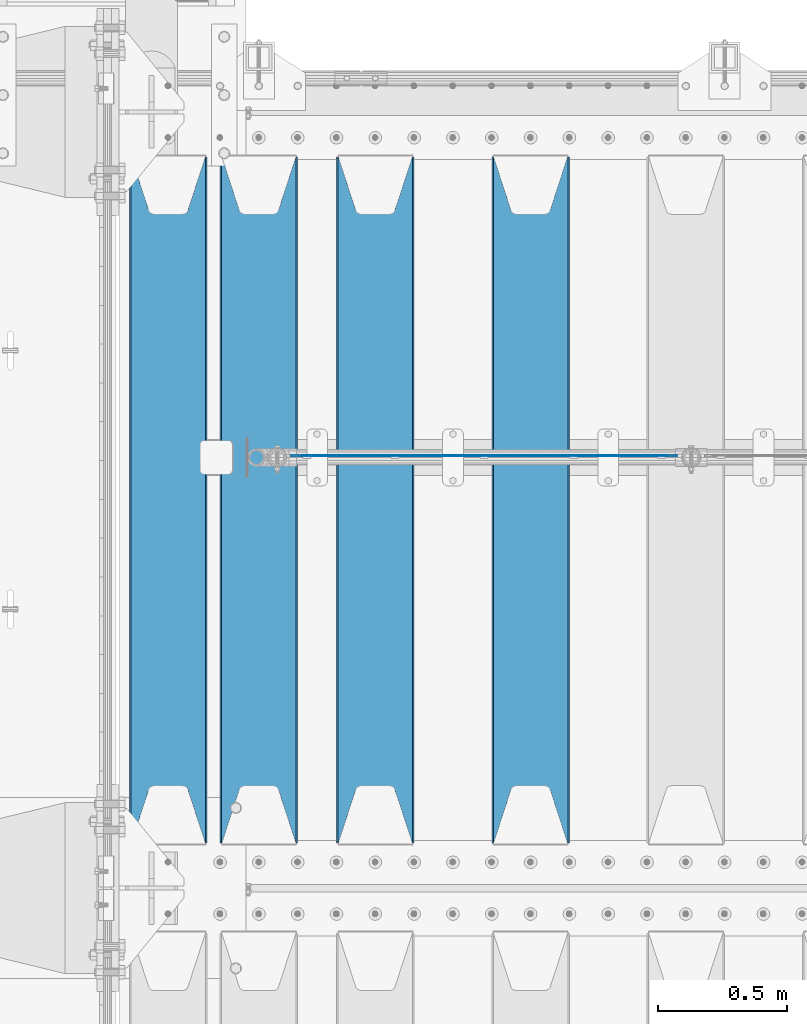
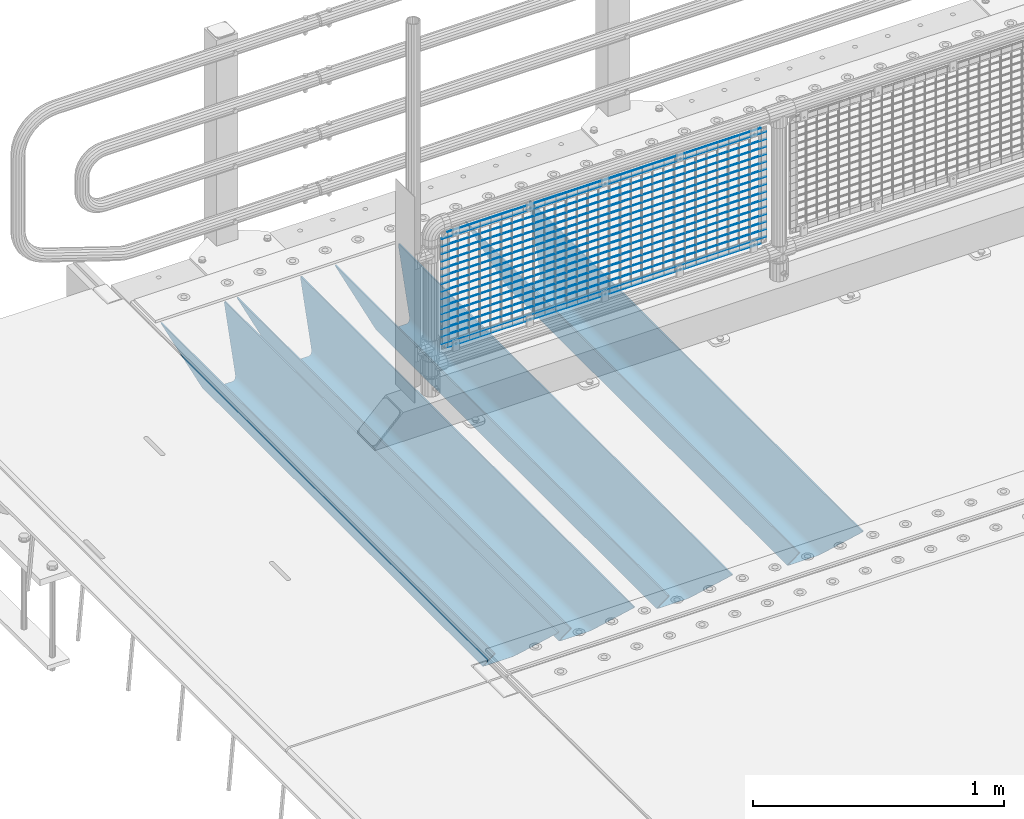
# One storey, part 93 of 208: 21 beams.
"""IFC2X3 building model written with IfcOpenShell, lengths in millimetres."""

from ifc_helpers import new_model, si_unit, frame, origin_with_axes, place, context, subcontext, project, spatial, faceted_brep, material, type_object, element, save


model = new_model("IFC2X3")

# Units and contexts
model_context = context("Model", 3, precision=1e-05, world=origin_with_axes())
body_context = subcontext(model_context, "Body", "Model", "MODEL_VIEW")
ifc_project = project(units=[si_unit("LENGTHUNIT", "METRE", prefix="MILLI"), si_unit("AREAUNIT", "SQUARE_METRE"), si_unit("VOLUMEUNIT", "CUBIC_METRE"), si_unit("MASSUNIT", "GRAM", prefix="KILO"), si_unit("TIMEUNIT", "SECOND"), si_unit("PLANEANGLEUNIT", "RADIAN"), si_unit("SOLIDANGLEUNIT", "STERADIAN"), si_unit("THERMODYNAMICTEMPERATUREUNIT", "DEGREE_CELSIUS"), si_unit("LUMINOUSINTENSITYUNIT", "LUMEN")], contexts=[model_context])

# Site, building, storey
site_placement = place(None, origin_with_axes())
site = spatial("IfcSite", under=ifc_project, at=site_placement, CompositionType="ELEMENT")
building_placement = place(site_placement, origin_with_axes())
building = spatial("IfcBuilding", under=site, at=building_placement, Name="Standard", CompositionType="ELEMENT")
storey_placement = place(building_placement, origin_with_axes())
storey = spatial("IfcBuildingStorey", under=building, at=storey_placement, Name="Undefined", CompositionType="ELEMENT", Elevation=0.0)

# Beams
ifc_material_1 = material(Name="STEEL/S355N")
beam_type_1 = type_object("IfcBeamType", PredefinedType="NOTDEFINED")
beam_1_placement = place(storey_placement, frame((-40850.0, 3175.0, -115.0), z_axis=(0.0, 0.0, 1.0), x_axis=(0.0, 1.0, 0.0)))
element("IfcBeam", 1, at=beam_1_placement, inside=storey, type_object=beam_type_1, material=ifc_material_1, context=body_context, shape_type="Brep", body=[
    faceted_brep([(0.0, 150.0, 115.0), (0.0, 143.689999999999, 115.0), (2650.00000000297, 143.689999999999, 115.0), (2650.00000000297, 150.0, 115.0), (2650.00000000297, 142.059565218402, 110.0000000031), (2650.00000000297, 148.369565218403, 110.0000000031), (2441.90079219208, -80.1103600731112, -98.0992078077845), (2437.7588105432, -77.5672621345584, -102.241189456673), (2434.06523489746, -74.4080125315522, -105.934765102404), (2430.91086095089, -70.710272125576, -109.089139048974), (2428.37322971128, -66.5649389910068, -111.626770288588), (2426.51472138055, -62.0739139532889, -113.485278619323), (2425.38102192091, -57.3475956567672, -114.618978078955), (2424.99999999987, -52.5021667386536, -115.0), (2424.99999999987, 52.5021667386536, -115.0), (2425.38102192091, 57.3475956567672, -114.618978078955), (2426.51472138055, 62.0739139532889, -113.485278619323), (2428.37322971128, 66.5649389910068, -111.626770288588), (2430.91086095089, 70.710272125576, -109.089139048974), (2434.06523489746, 74.4080125315522, -105.934765102404), (2437.7588105432, 77.5672621345584, -102.241189456673), (2441.90079219208, 80.1103600731112, -98.0992078077846), (2446.38936140511, 81.9747917625791, -93.6106385947584), (2448.24948500409, 76.2713538057251, -91.7505149957729), (2444.62967112262, 74.76777986261, -95.3703288772456), (2441.28936334126, 72.7168944282894, -98.710636658607), (2438.31067330438, 70.1691124903846, -101.689326695487), (2435.76682334747, 67.1870637758839, -104.233176652398), (2433.72034654133, 63.8440531834895, -106.279653458539), (2432.22154950041, 60.222258798236, -107.778450499454), (2431.30727574265, 56.4107117849089, -108.692724257221), (2430.99999999987, 52.5031078186876, -109.0), (2430.99999999987, -52.5031078186876, -109.0), (2431.30727574265, -56.4107117849089, -108.692724257221), (2432.22154950041, -60.222258798236, -107.778450499454), (2433.72034654133, -63.8440531834895, -106.279653458539), (2435.76682334747, -67.1870637758839, -104.233176652398), (2438.31067330438, -70.1691124903846, -101.689326695487), (2441.28936334126, -72.7168944282894, -98.7106366586071), (2444.62967112262, -74.76777986261, -95.3703288772457), (2448.24948500409, -76.2713538057251, -91.7505149957729), (2650.00000000297, -142.059565218402, 110.0000000031), (2650.00000000297, -148.369565218403, 110.0000000031), (2446.38936140511, -81.9747917625791, -93.6106385947584), (2650.00000000297, -143.689999999999, 115.0), (2650.00000000297, -150.0, 115.0), (0.0, -143.689999999999, 115.0), (0.0, -150.0, 115.0), (0.0, -148.369565218261, 110.000000002663), (203.610638597421, -81.9747917625791, -93.6106385947584), (208.099207810448, -80.1103600731112, -98.0992078077845), (212.241189459336, -77.5672621345584, -102.241189456673), (215.934765105067, -74.4080125315522, -105.934765102404), (219.089139051637, -70.710272125576, -109.089139048974), (221.626770291251, -66.5649389910068, -111.626770288588), (223.485278621986, -62.0739139532889, -113.485278619323), (224.618978081618, -57.3475956567672, -114.618978078955), (225.000000002663, -52.5021667386536, -115.0), (225.000000002663, 52.5021667386536, -115.0), (224.618978081618, 57.3475956567672, -114.618978078955), (223.485278621986, 62.0739139532889, -113.485278619323), (221.626770291251, 66.5649389910068, -111.626770288588), (219.089139051637, 70.710272125576, -109.089139048974), (215.934765105067, 74.4080125315522, -105.934765102404), (212.241189459336, 77.5672621345584, -102.241189456673), (208.099207810448, 80.1103600731112, -98.0992078077846), (203.610638597421, 81.9747917625791, -93.6106385947584), (0.0, 148.369565218261, 110.000000002663), (0.0, 142.05956521826, 110.000000002663), (201.750514998436, 76.2713538057251, -91.7505149957729), (205.370328879908, 74.76777986261, -95.3703288772456), (208.71063666127, 72.7168944282894, -98.710636658607), (211.68932669815, 70.1691124903846, -101.689326695487), (214.233176655061, 67.1870637758839, -104.233176652398), (216.279653461202, 63.8440531834895, -106.279653458539), (217.778450502116, 60.222258798236, -107.778450499454), (218.692724259884, 56.4107117849089, -108.692724257221), (219.000000002663, 52.5031078186876, -109.0), (219.000000002663, -52.5031078186876, -109.0), (218.692724259884, -56.4107117849089, -108.692724257221), (217.778450502116, -60.222258798236, -107.778450499454), (216.279653461202, -63.8440531834895, -106.279653458539), (214.233176655061, -67.1870637758839, -104.233176652398), (211.68932669815, -70.1691124903846, -101.689326695487), (208.71063666127, -72.7168944282894, -98.7106366586071), (205.370328879908, -74.76777986261, -95.3703288772457), (201.750514998436, -76.2713538057251, -91.7505149957729), (0.0, -142.05956521826, 110.000000002663)], [[[0, 1, 2, 3]], [[3, 2, 4, 5]], [[6, 7, 8, 9, 10, 11, 12, 13, 14, 15, 16, 17, 18, 19, 20, 21, 22, 5, 4, 23, 24, 25, 26, 27, 28, 29, 30, 31, 32, 33, 34, 35, 36, 37, 38, 39, 40, 41, 42, 43]], [[44, 45, 42, 41]], [[46, 47, 45, 44]], [[43, 42, 45, 47, 48, 49]], [[6, 43, 49, 50]], [[7, 6, 50, 51]], [[8, 7, 51, 52]], [[9, 8, 52, 53]], [[10, 9, 53, 54]], [[11, 10, 54, 55]], [[12, 11, 55, 56]], [[13, 12, 56, 57]], [[14, 13, 57, 58]], [[15, 14, 58, 59]], [[16, 15, 59, 60]], [[17, 16, 60, 61]], [[18, 17, 61, 62]], [[19, 18, 62, 63]], [[20, 19, 63, 64]], [[21, 20, 64, 65]], [[22, 21, 65, 66]], [[0, 3, 5, 22, 66, 67]], [[1, 0, 67, 68]], [[23, 4, 2, 1, 68, 69]], [[24, 23, 69, 70]], [[25, 24, 70, 71]], [[26, 25, 71, 72]], [[27, 26, 72, 73]], [[28, 27, 73, 74]], [[29, 28, 74, 75]], [[30, 29, 75, 76]], [[31, 30, 76, 77]], [[32, 31, 77, 78]], [[33, 32, 78, 79]], [[34, 33, 79, 80]], [[35, 34, 80, 81]], [[36, 35, 81, 82]], [[37, 36, 82, 83]], [[38, 37, 83, 84]], [[39, 38, 84, 85]], [[40, 39, 85, 86]], [[46, 44, 41, 40, 86, 87]], [[47, 46, 87, 48]], [[86, 85, 84, 83, 82, 81, 80, 79, 78, 77, 76, 75, 74, 73, 72, 71, 70, 69, 68, 67, 66, 65, 64, 63, 62, 61, 60, 59, 58, 57, 56, 55, 54, 53, 52, 51, 50, 49, 48, 87]]]),
])
beam_2_placement = place(storey_placement, frame((-41450.0, 3175.0, -115.0), z_axis=(0.0, 0.0, 1.0), x_axis=(0.0, 1.0, 0.0)))
element("IfcBeam", 2, at=beam_2_placement, inside=storey, type_object=beam_type_1, material=ifc_material_1, context=body_context, shape_type="Brep", body=[
    faceted_brep([(0.0, 150.0, 115.0), (0.0, 143.689999999999, 115.0), (2650.00000000297, 143.689999999999, 115.0), (2650.00000000297, 150.0, 115.0), (2650.00000000297, 142.059565218402, 110.0000000031), (2650.00000000297, 148.369565218403, 110.0000000031), (2441.90079219208, -80.1103600731112, -98.0992078077845), (2437.7588105432, -77.5672621345584, -102.241189456673), (2434.06523489746, -74.4080125315522, -105.934765102404), (2430.91086095089, -70.710272125576, -109.089139048974), (2428.37322971128, -66.5649389910068, -111.626770288588), (2426.51472138055, -62.0739139532889, -113.485278619323), (2425.38102192091, -57.3475956567672, -114.618978078955), (2424.99999999987, -52.5021667386536, -115.0), (2424.99999999987, 52.5021667386536, -115.0), (2425.38102192091, 57.3475956567672, -114.618978078955), (2426.51472138055, 62.0739139532889, -113.485278619323), (2428.37322971128, 66.5649389910068, -111.626770288588), (2430.91086095089, 70.710272125576, -109.089139048974), (2434.06523489746, 74.4080125315522, -105.934765102404), (2437.7588105432, 77.5672621345584, -102.241189456673), (2441.90079219208, 80.1103600731112, -98.0992078077846), (2446.38936140511, 81.9747917625791, -93.6106385947584), (2448.24948500409, 76.2713538057251, -91.7505149957729), (2444.62967112262, 74.76777986261, -95.3703288772456), (2441.28936334126, 72.7168944282894, -98.710636658607), (2438.31067330438, 70.1691124903846, -101.689326695487), (2435.76682334747, 67.1870637758839, -104.233176652398), (2433.72034654133, 63.8440531834895, -106.279653458539), (2432.22154950041, 60.222258798236, -107.778450499454), (2431.30727574265, 56.4107117849089, -108.692724257221), (2430.99999999987, 52.5031078186876, -109.0), (2430.99999999987, -52.5031078186876, -109.0), (2431.30727574265, -56.4107117849089, -108.692724257221), (2432.22154950041, -60.222258798236, -107.778450499454), (2433.72034654133, -63.8440531834895, -106.279653458539), (2435.76682334747, -67.1870637758839, -104.233176652398), (2438.31067330438, -70.1691124903846, -101.689326695487), (2441.28936334126, -72.7168944282894, -98.7106366586071), (2444.62967112262, -74.76777986261, -95.3703288772457), (2448.24948500409, -76.2713538057251, -91.7505149957729), (2650.00000000297, -142.059565218402, 110.0000000031), (2650.00000000297, -148.369565218403, 110.0000000031), (2446.38936140511, -81.9747917625791, -93.6106385947584), (2650.00000000297, -143.689999999999, 115.0), (2650.00000000297, -150.0, 115.0), (0.0, -143.689999999999, 115.0), (0.0, -150.0, 115.0), (0.0, -148.369565218261, 110.000000002663), (203.610638597421, -81.9747917625791, -93.6106385947584), (208.099207810448, -80.1103600731112, -98.0992078077845), (212.241189459336, -77.5672621345584, -102.241189456673), (215.934765105067, -74.4080125315522, -105.934765102404), (219.089139051637, -70.710272125576, -109.089139048974), (221.626770291251, -66.5649389910068, -111.626770288588), (223.485278621986, -62.0739139532889, -113.485278619323), (224.618978081618, -57.3475956567672, -114.618978078955), (225.000000002663, -52.5021667386536, -115.0), (225.000000002663, 52.5021667386536, -115.0), (224.618978081618, 57.3475956567672, -114.618978078955), (223.485278621986, 62.0739139532889, -113.485278619323), (221.626770291251, 66.5649389910068, -111.626770288588), (219.089139051637, 70.710272125576, -109.089139048974), (215.934765105067, 74.4080125315522, -105.934765102404), (212.241189459336, 77.5672621345584, -102.241189456673), (208.099207810448, 80.1103600731112, -98.0992078077846), (203.610638597421, 81.9747917625791, -93.6106385947584), (0.0, 148.369565218261, 110.000000002663), (0.0, 142.05956521826, 110.000000002663), (201.750514998436, 76.2713538057251, -91.7505149957729), (205.370328879908, 74.76777986261, -95.3703288772456), (208.71063666127, 72.7168944282894, -98.710636658607), (211.68932669815, 70.1691124903846, -101.689326695487), (214.233176655061, 67.1870637758839, -104.233176652398), (216.279653461202, 63.8440531834895, -106.279653458539), (217.778450502116, 60.222258798236, -107.778450499454), (218.692724259884, 56.4107117849089, -108.692724257221), (219.000000002663, 52.5031078186876, -109.0), (219.000000002663, -52.5031078186876, -109.0), (218.692724259884, -56.4107117849089, -108.692724257221), (217.778450502116, -60.222258798236, -107.778450499454), (216.279653461202, -63.8440531834895, -106.279653458539), (214.233176655061, -67.1870637758839, -104.233176652398), (211.68932669815, -70.1691124903846, -101.689326695487), (208.71063666127, -72.7168944282894, -98.7106366586071), (205.370328879908, -74.76777986261, -95.3703288772457), (201.750514998436, -76.2713538057251, -91.7505149957729), (0.0, -142.05956521826, 110.000000002663)], [[[0, 1, 2, 3]], [[3, 2, 4, 5]], [[6, 7, 8, 9, 10, 11, 12, 13, 14, 15, 16, 17, 18, 19, 20, 21, 22, 5, 4, 23, 24, 25, 26, 27, 28, 29, 30, 31, 32, 33, 34, 35, 36, 37, 38, 39, 40, 41, 42, 43]], [[44, 45, 42, 41]], [[46, 47, 45, 44]], [[43, 42, 45, 47, 48, 49]], [[6, 43, 49, 50]], [[7, 6, 50, 51]], [[8, 7, 51, 52]], [[9, 8, 52, 53]], [[10, 9, 53, 54]], [[11, 10, 54, 55]], [[12, 11, 55, 56]], [[13, 12, 56, 57]], [[14, 13, 57, 58]], [[15, 14, 58, 59]], [[16, 15, 59, 60]], [[17, 16, 60, 61]], [[18, 17, 61, 62]], [[19, 18, 62, 63]], [[20, 19, 63, 64]], [[21, 20, 64, 65]], [[22, 21, 65, 66]], [[0, 3, 5, 22, 66, 67]], [[1, 0, 67, 68]], [[23, 4, 2, 1, 68, 69]], [[24, 23, 69, 70]], [[25, 24, 70, 71]], [[26, 25, 71, 72]], [[27, 26, 72, 73]], [[28, 27, 73, 74]], [[29, 28, 74, 75]], [[30, 29, 75, 76]], [[31, 30, 76, 77]], [[32, 31, 77, 78]], [[33, 32, 78, 79]], [[34, 33, 79, 80]], [[35, 34, 80, 81]], [[36, 35, 81, 82]], [[37, 36, 82, 83]], [[38, 37, 83, 84]], [[39, 38, 84, 85]], [[40, 39, 85, 86]], [[46, 44, 41, 40, 86, 87]], [[47, 46, 87, 48]], [[86, 85, 84, 83, 82, 81, 80, 79, 78, 77, 76, 75, 74, 73, 72, 71, 70, 69, 68, 67, 66, 65, 64, 63, 62, 61, 60, 59, 58, 57, 56, 55, 54, 53, 52, 51, 50, 49, 48, 87]]]),
])
beam_3_placement = place(storey_placement, frame((-41900.0, 3175.0, -115.0), z_axis=(0.0, 0.0, 1.0), x_axis=(0.0, 1.0, 0.0)))
element("IfcBeam", 3, at=beam_3_placement, inside=storey, type_object=beam_type_1, material=ifc_material_1, context=body_context, shape_type="Brep", body=[
    faceted_brep([(0.0, 150.0, 115.0), (0.0, 143.689999999999, 115.0), (2650.00000000297, 143.689999999999, 115.0), (2650.00000000297, 150.0, 115.0), (2650.00000000297, 142.059565218402, 110.0000000031), (2650.00000000297, 148.369565218403, 110.0000000031), (2441.90079219208, -80.1103600731112, -98.0992078077845), (2437.7588105432, -77.5672621345584, -102.241189456673), (2434.06523489746, -74.4080125315522, -105.934765102404), (2430.91086095089, -70.710272125576, -109.089139048974), (2428.37322971128, -66.5649389910068, -111.626770288588), (2426.51472138055, -62.0739139532889, -113.485278619323), (2425.38102192091, -57.3475956567672, -114.618978078955), (2424.99999999987, -52.5021667386536, -115.0), (2424.99999999987, 52.5021667386536, -115.0), (2425.38102192091, 57.3475956567672, -114.618978078955), (2426.51472138055, 62.0739139532889, -113.485278619323), (2428.37322971128, 66.5649389910068, -111.626770288588), (2430.91086095089, 70.710272125576, -109.089139048974), (2434.06523489746, 74.4080125315522, -105.934765102404), (2437.7588105432, 77.5672621345584, -102.241189456673), (2441.90079219208, 80.1103600731112, -98.0992078077846), (2446.38936140511, 81.9747917625791, -93.6106385947584), (2448.24948500409, 76.2713538057251, -91.7505149957729), (2444.62967112262, 74.76777986261, -95.3703288772456), (2441.28936334126, 72.7168944282894, -98.710636658607), (2438.31067330438, 70.1691124903846, -101.689326695487), (2435.76682334747, 67.1870637758839, -104.233176652398), (2433.72034654133, 63.8440531834895, -106.279653458539), (2432.22154950041, 60.222258798236, -107.778450499454), (2431.30727574265, 56.4107117849089, -108.692724257221), (2430.99999999987, 52.5031078186876, -109.0), (2430.99999999987, -52.5031078186876, -109.0), (2431.30727574265, -56.4107117849089, -108.692724257221), (2432.22154950041, -60.222258798236, -107.778450499454), (2433.72034654133, -63.8440531834895, -106.279653458539), (2435.76682334747, -67.1870637758839, -104.233176652398), (2438.31067330438, -70.1691124903846, -101.689326695487), (2441.28936334126, -72.7168944282894, -98.7106366586071), (2444.62967112262, -74.76777986261, -95.3703288772457), (2448.24948500409, -76.2713538057251, -91.7505149957729), (2650.00000000297, -142.059565218402, 110.0000000031), (2650.00000000297, -148.369565218403, 110.0000000031), (2446.38936140511, -81.9747917625791, -93.6106385947584), (2650.00000000297, -143.689999999999, 115.0), (2650.00000000297, -150.0, 115.0), (0.0, -143.689999999999, 115.0), (0.0, -150.0, 115.0), (0.0, -148.369565218261, 110.000000002663), (203.610638597421, -81.9747917625791, -93.6106385947584), (208.099207810448, -80.1103600731112, -98.0992078077845), (212.241189459336, -77.5672621345584, -102.241189456673), (215.934765105067, -74.4080125315522, -105.934765102404), (219.089139051637, -70.710272125576, -109.089139048974), (221.626770291251, -66.5649389910068, -111.626770288588), (223.485278621986, -62.0739139532889, -113.485278619323), (224.618978081618, -57.3475956567672, -114.618978078955), (225.000000002663, -52.5021667386536, -115.0), (225.000000002663, 52.5021667386536, -115.0), (224.618978081618, 57.3475956567672, -114.618978078955), (223.485278621986, 62.0739139532889, -113.485278619323), (221.626770291251, 66.5649389910068, -111.626770288588), (219.089139051637, 70.710272125576, -109.089139048974), (215.934765105067, 74.4080125315522, -105.934765102404), (212.241189459336, 77.5672621345584, -102.241189456673), (208.099207810448, 80.1103600731112, -98.0992078077846), (203.610638597421, 81.9747917625791, -93.6106385947584), (0.0, 148.369565218261, 110.000000002663), (0.0, 142.05956521826, 110.000000002663), (201.750514998436, 76.2713538057251, -91.7505149957729), (205.370328879908, 74.76777986261, -95.3703288772456), (208.71063666127, 72.7168944282894, -98.710636658607), (211.68932669815, 70.1691124903846, -101.689326695487), (214.233176655061, 67.1870637758839, -104.233176652398), (216.279653461202, 63.8440531834895, -106.279653458539), (217.778450502116, 60.222258798236, -107.778450499454), (218.692724259884, 56.4107117849089, -108.692724257221), (219.000000002663, 52.5031078186876, -109.0), (219.000000002663, -52.5031078186876, -109.0), (218.692724259884, -56.4107117849089, -108.692724257221), (217.778450502116, -60.222258798236, -107.778450499454), (216.279653461202, -63.8440531834895, -106.279653458539), (214.233176655061, -67.1870637758839, -104.233176652398), (211.68932669815, -70.1691124903846, -101.689326695487), (208.71063666127, -72.7168944282894, -98.7106366586071), (205.370328879908, -74.76777986261, -95.3703288772457), (201.750514998436, -76.2713538057251, -91.7505149957729), (0.0, -142.05956521826, 110.000000002663)], [[[0, 1, 2, 3]], [[3, 2, 4, 5]], [[6, 7, 8, 9, 10, 11, 12, 13, 14, 15, 16, 17, 18, 19, 20, 21, 22, 5, 4, 23, 24, 25, 26, 27, 28, 29, 30, 31, 32, 33, 34, 35, 36, 37, 38, 39, 40, 41, 42, 43]], [[44, 45, 42, 41]], [[46, 47, 45, 44]], [[43, 42, 45, 47, 48, 49]], [[6, 43, 49, 50]], [[7, 6, 50, 51]], [[8, 7, 51, 52]], [[9, 8, 52, 53]], [[10, 9, 53, 54]], [[11, 10, 54, 55]], [[12, 11, 55, 56]], [[13, 12, 56, 57]], [[14, 13, 57, 58]], [[15, 14, 58, 59]], [[16, 15, 59, 60]], [[17, 16, 60, 61]], [[18, 17, 61, 62]], [[19, 18, 62, 63]], [[20, 19, 63, 64]], [[21, 20, 64, 65]], [[22, 21, 65, 66]], [[0, 3, 5, 22, 66, 67]], [[1, 0, 67, 68]], [[23, 4, 2, 1, 68, 69]], [[24, 23, 69, 70]], [[25, 24, 70, 71]], [[26, 25, 71, 72]], [[27, 26, 72, 73]], [[28, 27, 73, 74]], [[29, 28, 74, 75]], [[30, 29, 75, 76]], [[31, 30, 76, 77]], [[32, 31, 77, 78]], [[33, 32, 78, 79]], [[34, 33, 79, 80]], [[35, 34, 80, 81]], [[36, 35, 81, 82]], [[37, 36, 82, 83]], [[38, 37, 83, 84]], [[39, 38, 84, 85]], [[40, 39, 85, 86]], [[46, 44, 41, 40, 86, 87]], [[47, 46, 87, 48]], [[86, 85, 84, 83, 82, 81, 80, 79, 78, 77, 76, 75, 74, 73, 72, 71, 70, 69, 68, 67, 66, 65, 64, 63, 62, 61, 60, 59, 58, 57, 56, 55, 54, 53, 52, 51, 50, 49, 48, 87]]]),
])
beam_4_placement = place(storey_placement, frame((-42250.0, 3175.0, -115.0), z_axis=(0.0, 0.0, 1.0), x_axis=(0.0, 1.0, 0.0)))
element("IfcBeam", 4, at=beam_4_placement, inside=storey, type_object=beam_type_1, material=ifc_material_1, context=body_context, shape_type="Brep", body=[
    faceted_brep([(0.0, 150.0, 115.0), (0.0, 143.689999999999, 115.0), (2650.00000000297, 143.689999999999, 115.0), (2650.00000000297, 150.0, 115.0), (2650.00000000297, 142.059565218402, 110.0000000031), (2650.00000000297, 148.369565218403, 110.0000000031), (2441.90079219208, -80.1103600731112, -98.0992078077845), (2437.7588105432, -77.5672621345584, -102.241189456673), (2434.06523489746, -74.4080125315522, -105.934765102404), (2430.91086095089, -70.710272125576, -109.089139048974), (2428.37322971128, -66.5649389910068, -111.626770288588), (2426.51472138055, -62.0739139532889, -113.485278619323), (2425.38102192091, -57.3475956567672, -114.618978078955), (2424.99999999987, -52.5021667386536, -115.0), (2424.99999999987, 52.5021667386536, -115.0), (2425.38102192091, 57.3475956567672, -114.618978078955), (2426.51472138055, 62.0739139532889, -113.485278619323), (2428.37322971128, 66.5649389910068, -111.626770288588), (2430.91086095089, 70.710272125576, -109.089139048974), (2434.06523489746, 74.4080125315522, -105.934765102404), (2437.7588105432, 77.5672621345584, -102.241189456673), (2441.90079219208, 80.1103600731112, -98.0992078077846), (2446.38936140511, 81.9747917625791, -93.6106385947584), (2448.24948500409, 76.2713538057251, -91.7505149957729), (2444.62967112262, 74.76777986261, -95.3703288772456), (2441.28936334126, 72.7168944282894, -98.710636658607), (2438.31067330438, 70.1691124903846, -101.689326695487), (2435.76682334747, 67.1870637758839, -104.233176652398), (2433.72034654133, 63.8440531834895, -106.279653458539), (2432.22154950041, 60.222258798236, -107.778450499454), (2431.30727574265, 56.4107117849089, -108.692724257221), (2430.99999999987, 52.5031078186876, -109.0), (2430.99999999987, -52.5031078186876, -109.0), (2431.30727574265, -56.4107117849089, -108.692724257221), (2432.22154950041, -60.222258798236, -107.778450499454), (2433.72034654133, -63.8440531834895, -106.279653458539), (2435.76682334747, -67.1870637758839, -104.233176652398), (2438.31067330438, -70.1691124903846, -101.689326695487), (2441.28936334126, -72.7168944282894, -98.7106366586071), (2444.62967112262, -74.76777986261, -95.3703288772457), (2448.24948500409, -76.2713538057251, -91.7505149957729), (2650.00000000297, -142.059565218402, 110.0000000031), (2650.00000000297, -148.369565218403, 110.0000000031), (2446.38936140511, -81.9747917625791, -93.6106385947584), (2650.00000000297, -143.689999999999, 115.0), (2650.00000000297, -150.0, 115.0), (0.0, -143.689999999999, 115.0), (0.0, -150.0, 115.0), (0.0, -148.369565218261, 110.000000002663), (203.610638597421, -81.9747917625791, -93.6106385947584), (208.099207810448, -80.1103600731112, -98.0992078077845), (212.241189459336, -77.5672621345584, -102.241189456673), (215.934765105067, -74.4080125315522, -105.934765102404), (219.089139051637, -70.710272125576, -109.089139048974), (221.626770291251, -66.5649389910068, -111.626770288588), (223.485278621986, -62.0739139532889, -113.485278619323), (224.618978081618, -57.3475956567672, -114.618978078955), (225.000000002663, -52.5021667386536, -115.0), (225.000000002663, 52.5021667386536, -115.0), (224.618978081618, 57.3475956567672, -114.618978078955), (223.485278621986, 62.0739139532889, -113.485278619323), (221.626770291251, 66.5649389910068, -111.626770288588), (219.089139051637, 70.710272125576, -109.089139048974), (215.934765105067, 74.4080125315522, -105.934765102404), (212.241189459336, 77.5672621345584, -102.241189456673), (208.099207810448, 80.1103600731112, -98.0992078077846), (203.610638597421, 81.9747917625791, -93.6106385947584), (0.0, 148.369565218261, 110.000000002663), (0.0, 142.05956521826, 110.000000002663), (201.750514998436, 76.2713538057251, -91.7505149957729), (205.370328879908, 74.76777986261, -95.3703288772456), (208.71063666127, 72.7168944282894, -98.710636658607), (211.68932669815, 70.1691124903846, -101.689326695487), (214.233176655061, 67.1870637758839, -104.233176652398), (216.279653461202, 63.8440531834895, -106.279653458539), (217.778450502116, 60.222258798236, -107.778450499454), (218.692724259884, 56.4107117849089, -108.692724257221), (219.000000002663, 52.5031078186876, -109.0), (219.000000002663, -52.5031078186876, -109.0), (218.692724259884, -56.4107117849089, -108.692724257221), (217.778450502116, -60.222258798236, -107.778450499454), (216.279653461202, -63.8440531834895, -106.279653458539), (214.233176655061, -67.1870637758839, -104.233176652398), (211.68932669815, -70.1691124903846, -101.689326695487), (208.71063666127, -72.7168944282894, -98.7106366586071), (205.370328879908, -74.76777986261, -95.3703288772457), (201.750514998436, -76.2713538057251, -91.7505149957729), (0.0, -142.05956521826, 110.000000002663)], [[[0, 1, 2, 3]], [[3, 2, 4, 5]], [[6, 7, 8, 9, 10, 11, 12, 13, 14, 15, 16, 17, 18, 19, 20, 21, 22, 5, 4, 23, 24, 25, 26, 27, 28, 29, 30, 31, 32, 33, 34, 35, 36, 37, 38, 39, 40, 41, 42, 43]], [[44, 45, 42, 41]], [[46, 47, 45, 44]], [[43, 42, 45, 47, 48, 49]], [[6, 43, 49, 50]], [[7, 6, 50, 51]], [[8, 7, 51, 52]], [[9, 8, 52, 53]], [[10, 9, 53, 54]], [[11, 10, 54, 55]], [[12, 11, 55, 56]], [[13, 12, 56, 57]], [[14, 13, 57, 58]], [[15, 14, 58, 59]], [[16, 15, 59, 60]], [[17, 16, 60, 61]], [[18, 17, 61, 62]], [[19, 18, 62, 63]], [[20, 19, 63, 64]], [[21, 20, 64, 65]], [[22, 21, 65, 66]], [[0, 3, 5, 22, 66, 67]], [[1, 0, 67, 68]], [[23, 4, 2, 1, 68, 69]], [[24, 23, 69, 70]], [[25, 24, 70, 71]], [[26, 25, 71, 72]], [[27, 26, 72, 73]], [[28, 27, 73, 74]], [[29, 28, 74, 75]], [[30, 29, 75, 76]], [[31, 30, 76, 77]], [[32, 31, 77, 78]], [[33, 32, 78, 79]], [[34, 33, 79, 80]], [[35, 34, 80, 81]], [[36, 35, 81, 82]], [[37, 36, 82, 83]], [[38, 37, 83, 84]], [[39, 38, 84, 85]], [[40, 39, 85, 86]], [[46, 44, 41, 40, 86, 87]], [[47, 46, 87, 48]], [[86, 85, 84, 83, 82, 81, 80, 79, 78, 77, 76, 75, 74, 73, 72, 71, 70, 69, 68, 67, 66, 65, 64, 63, 62, 61, 60, 59, 58, 57, 56, 55, 54, 53, 52, 51, 50, 49, 48, 87]]]),
])
ifc_material_2 = material(Name="Misc_Undefined")
beam_type_2 = type_object("IfcBeamType", Name="D3", PredefinedType="NOTDEFINED")
for number, where, z_axis, x_axis in (
    (5, (-41774.0, 4670.5, 851.596999999999), (0.0, 0.0, 1.0), (1.0, 0.0, 0.0)),
    (6, (-41774.0, 4670.5, 669.452), (0.0, 0.0, 1.0), (1.0, 0.0, 0.0)),
    (7, (-41774.0, 4670.5, 523.736), (0.0, 0.0, 1.0), (1.0, 0.0, 0.0)),
    (8, (-41774.0, 4670.5, 487.307), (0.0, 0.0, 1.0), (1.0, 0.0, 0.0)),
    (9, (-41774.0, 4670.5, 705.881), (0.0, 0.0, 1.0), (1.0, 0.0, 0.0)),
    (10, (-41774.0, 4670.5, 596.594), (0.0, 0.0, 1.0), (1.0, 0.0, 0.0)),
    (11, (-41774.0, 4670.5, 450.878), (0.0, 0.0, 1.0), (1.0, 0.0, 0.0)),
    (12, (-41774.0, 4670.5, 815.167999999999), (0.0, 0.0, 1.0), (1.0, 0.0, 0.0)),
    (13, (-41774.0, 4670.5, 888.025999999999), (0.0, 0.0, 1.0), (1.0, 0.0, 0.0)),
    (14, (-41774.0, 4670.5, 778.738999999999), (0.0, 0.0, 1.0), (1.0, 0.0, 0.0)),
    (15, (-41774.0, 4670.5, 742.309999999999), (0.0, 0.0, 1.0), (1.0, 0.0, 0.0)),
    (16, (-41774.0, 4670.5, 633.023), (0.0, 0.0, 1.0), (1.0, 0.0, 0.0)),
    (17, (-41774.0, 4670.5, 560.165), (0.0, 0.0, 1.0), (1.0, 0.0, 0.0)),
    (18, (-41774.0, 4670.5, 414.449), (0.0, 0.0, 1.0), (1.0, 0.0, 0.0)),
):
    element("IfcBeam", number, at=place(storey_placement, frame(where, z_axis=z_axis, x_axis=x_axis)), inside=storey, type_object=beam_type_2, material=ifc_material_2, ObjectType="D3", context=body_context, shape_type="Brep", body=[
        faceted_brep([(0.0, -1.49999999999909, 3.63797880709171e-12), (-7.27595761418343e-12, -0.749999999999091, -1.29903810567669), (1490.0, -0.75, -1.29903810567669), (1490.0, -1.5, 0.0), (-3.63797880709171e-12, 0.750000000000909, -1.29903810567669), (1490.0, 0.75, -1.29903810567669), (0.0, 1.50000000000182, 3.63797880709171e-12), (1490.0, 1.5, 0.0), (-3.63797880709171e-12, 0.750000000000909, 1.29903810567669), (1490.0, 0.75, 1.29903810567669), (-7.27595761418343e-12, -0.749999999999091, 1.29903810567669), (1490.0, -0.75, 1.29903810567669)], [[[0, 1, 2, 3]], [[1, 4, 5, 2]], [[4, 6, 7, 5]], [[6, 8, 9, 7]], [[8, 10, 11, 9]], [[10, 0, 3, 11]], [[5, 7, 9, 11, 3, 2]], [[10, 8, 6, 4, 1, 0]]]),
    ])
beam_5_placement = place(storey_placement, frame((-41749.0, 4670.5, 353.02), z_axis=(0.0, 0.0, 1.0), x_axis=(1.0, 0.0, 0.0)))
element("IfcBeam", 19, at=beam_5_placement, inside=storey, type_object=beam_type_2, material=ifc_material_2, ObjectType="D3", context=body_context, shape_type="Brep", body=[
    faceted_brep([(0.0, -1.49999999999909, 3.63797880709171e-12), (-7.27595761418343e-12, -0.749999999999091, -1.29903810567669), (1440.0, -0.75, -1.29903810567669), (1440.0, -1.5, 0.0), (-3.63797880709171e-12, 0.750000000000909, -1.29903810567669), (1440.0, 0.75, -1.29903810567663), (0.0, 1.50000000000182, 3.63797880709171e-12), (1440.0, 1.5, 0.0), (-3.63797880709171e-12, 0.750000000000909, 1.29903810567669), (1440.0, 0.75, 1.29903810567669), (-7.27595761418343e-12, -0.749999999999091, 1.29903810567669), (1440.0, -0.75, 1.29903810567669)], [[[0, 1, 2, 3]], [[1, 4, 5, 2]], [[4, 6, 7, 5]], [[6, 8, 9, 7]], [[8, 10, 11, 9]], [[10, 0, 3, 11]], [[5, 7, 9, 11, 3, 2]], [[10, 8, 6, 4, 1, 0]]]),
])
beam_6_placement = place(storey_placement, frame((-41774.0, 4670.5, 378.02), z_axis=(0.0, 0.0, 1.0), x_axis=(1.0, 0.0, 0.0)))
element("IfcBeam", 20, at=beam_6_placement, inside=storey, type_object=beam_type_2, material=ifc_material_2, ObjectType="D3", context=body_context, shape_type="Brep", body=[
    faceted_brep([(0.0, -1.49999999999909, 3.63797880709171e-12), (-7.27595761418343e-12, -0.749999999999091, -1.29903810567669), (1490.0, -0.75, -1.29903810567669), (1490.0, -1.5, 0.0), (-3.63797880709171e-12, 0.750000000000909, -1.29903810567669), (1490.0, 0.75, -1.29903810567669), (0.0, 1.50000000000182, 3.63797880709171e-12), (1490.0, 1.5, 0.0), (-3.63797880709171e-12, 0.750000000000909, 1.29903810567669), (1490.0, 0.75, 1.29903810567669), (-7.27595761418343e-12, -0.749999999999091, 1.29903810567669), (1490.0, -0.75, 1.29903810567669)], [[[0, 1, 2, 3]], [[1, 4, 5, 2]], [[4, 6, 7, 5]], [[6, 8, 9, 7]], [[8, 10, 11, 9]], [[10, 0, 3, 11]], [[5, 7, 9, 11, 3, 2]], [[10, 8, 6, 4, 1, 0]]]),
])
beam_7_placement = place(storey_placement, frame((-41749.0, 4670.5, 913.02), z_axis=(0.0, 0.0, 1.0), x_axis=(1.0, 0.0, 0.0)))
element("IfcBeam", 21, at=beam_7_placement, inside=storey, type_object=beam_type_2, material=ifc_material_2, ObjectType="D3", context=body_context, shape_type="Brep", body=[
    faceted_brep([(0.0, -1.49999999999909, 3.63797880709171e-12), (-7.27595761418343e-12, -0.749999999999091, -1.29903810567669), (1440.0, -0.75, -1.29903810567669), (1440.0, -1.5, 0.0), (-3.63797880709171e-12, 0.750000000000909, -1.29903810567669), (1440.0, 0.75, -1.29903810567663), (0.0, 1.50000000000182, 3.63797880709171e-12), (1440.0, 1.5, 0.0), (-3.63797880709171e-12, 0.750000000000909, 1.29903810567669), (1440.0, 0.75, 1.29903810567669), (-7.27595761418343e-12, -0.749999999999091, 1.29903810567669), (1440.0, -0.75, 1.29903810567669)], [[[0, 1, 2, 3]], [[1, 4, 5, 2]], [[4, 6, 7, 5]], [[6, 8, 9, 7]], [[8, 10, 11, 9]], [[10, 0, 3, 11]], [[5, 7, 9, 11, 3, 2]], [[10, 8, 6, 4, 1, 0]]]),
])

save(model, "model.ifc")
